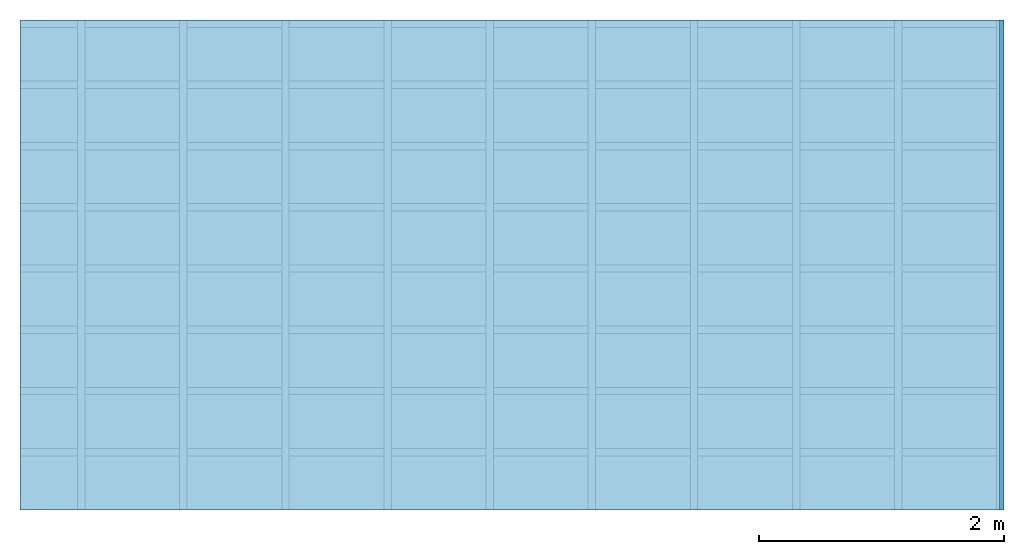
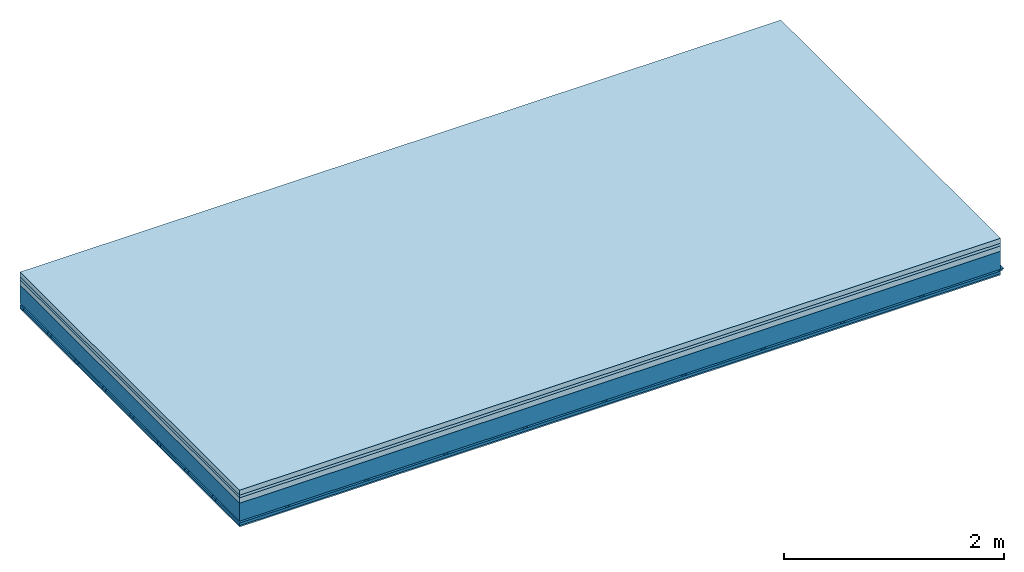
# One storey: 4 members, 4 plates, 1 element without a shape of its own.
"""IFC4 building model written with IfcOpenShell, lengths in metres."""

import ifcopenshell
import ifcopenshell.guid

model = None  # the IFC model being written
_history = None  # IfcOwnerHistory: only IFC2X3 demands one
_inside = {}  # id of a spatial element -> (the spatial element, [elements in it])
_under = {}  # id of a project, library or spatial element -> (it, [spatial elements below it])
_declared = {}  # id of a project -> (the project, [libraries it declares])
_typed = {}  # id of a type object -> (the type object, [elements of that type])
_made_of = {}  # id of a material, layer set ... -> (it, [elements and type objects made of it])


def new_model(schema):
    """Start an empty IFC model of exactly this schema.

    Asked for "IFC4X3", IfcOpenShell would pick the latest addendum, in which some entities
    have other attributes; the version numbers below select the first issue.
    IFC2X3 requires an IfcOwnerHistory on every rooted entity: one is made here for all.
    """
    global model, _history
    if schema == "IFC4X3":
        model = ifcopenshell.file(schema_version=(4, 3, 0, 0))
    else:
        model = ifcopenshell.file(schema=schema)
    _inside.clear()
    _under.clear()
    _declared.clear()
    _typed.clear()
    _made_of.clear()
    _history = None
    if model.schema == "IFC2X3":
        org = make("IfcOrganization", Name="unknown")
        user = make(
            "IfcPersonAndOrganization",
            ThePerson=make("IfcPerson", FamilyName="unknown"),
            TheOrganization=org,
        )
        app = make(
            "IfcApplication",
            ApplicationDeveloper=org,
            Version="unknown",
            ApplicationFullName="unknown",
            ApplicationIdentifier="unknown",
        )
        _history = make(
            "IfcOwnerHistory",
            OwningUser=user,
            OwningApplication=app,
            ChangeAction="ADDED",
            CreationDate=0,
        )
    return model


def make(cls, **values):
    """One entity of the class cls with the attributes given. An attribute that is None is left unset."""
    return model.create_entity(
        cls, **{name: value for name, value in values.items() if value is not None}
    )


def rooted(cls, **values):
    """An entity with a GlobalId (a new one), such as an element, a storey or a relation."""
    return make(cls, GlobalId=ifcopenshell.guid.new(), OwnerHistory=_history, **values)


def si_unit(unit_type, name, prefix=None):
    """IfcSIUnit, for example si_unit("LENGTHUNIT", "METRE", prefix="MILLI")."""
    return make("IfcSIUnit", UnitType=unit_type, Prefix=prefix, Name=name)


def derived_unit(unit_type, elements):
    """IfcDerivedUnit: a product of units, each with its exponent."""
    return make(
        "IfcDerivedUnit",
        Elements=[
            make("IfcDerivedUnitElement", Unit=unit, Exponent=power)
            for unit, power in elements
        ],
        UnitType=unit_type,
    )


def assignment(units):
    """IfcUnitAssignment: the units of a project."""
    return None if units is None else make("IfcUnitAssignment", Units=units)


def point(xyz):
    """IfcCartesianPoint."""
    return None if xyz is None else make("IfcCartesianPoint", Coordinates=xyz)


def direction(xyz):
    """IfcDirection."""
    return None if xyz is None else make("IfcDirection", DirectionRatios=xyz)


def frame(location, z_axis=None, x_axis=None):
    """IfcAxis2Placement3D, a coordinate frame: its origin and axes. An axis left out is left unset."""
    return make(
        "IfcAxis2Placement3D",
        Location=point(location),
        Axis=direction(z_axis),
        RefDirection=direction(x_axis),
    )


def frame_2d(location, x_axis=None):
    """IfcAxis2Placement2D, a coordinate frame in the plane: its origin and x axis."""
    return make(
        "IfcAxis2Placement2D", Location=point(location), RefDirection=direction(x_axis)
    )


def origin():
    """The frame at (0, 0, 0) with its axes left unset."""
    return frame((0.0, 0.0, 0.0))


def origin_with_axes():
    """The frame at (0, 0, 0) with the z axis (0, 0, 1) and the x axis (1, 0, 0) written out."""
    return frame((0.0, 0.0, 0.0), z_axis=(0.0, 0.0, 1.0), x_axis=(1.0, 0.0, 0.0))


def place(relative_to, where):
    """IfcLocalPlacement: puts the frame where relative to a parent placement (None: the world)."""
    return make(
        "IfcLocalPlacement", PlacementRelTo=relative_to, RelativePlacement=where
    )


def context(
    kind, dimensions, precision=None, world=None, true_north=None, identifier=None
):
    """IfcGeometricRepresentationContext, for example the 3D "Model" context."""
    return make(
        "IfcGeometricRepresentationContext",
        ContextIdentifier=identifier,
        ContextType=kind,
        CoordinateSpaceDimension=dimensions,
        Precision=precision,
        WorldCoordinateSystem=world,
        TrueNorth=true_north,
    )


def project(units=None, contexts=None):
    """IfcProject with its units and contexts."""
    return rooted(
        "IfcProject",
        Name="project",
        RepresentationContexts=contexts,
        UnitsInContext=assignment(units),
    )


def spatial(cls, under=None, at=None, **own):
    """A site, building, storey or space (cls), placed at a placement, below another one or the project."""
    s = rooted(cls, ObjectPlacement=at, **own)
    if under is not None:
        _under.setdefault(under.id(), (under, []))[1].append(s)
    return s


def polyline(points):
    """IfcPolyline through the points."""
    return make("IfcPolyline", Points=[point(p) for p in points])


def profile(cls, at=None, kind="AREA", **sizes):
    """A parametric profile (cls). Its sizes go by their IFC names, for example OverallWidth=200.0."""
    return make(cls, ProfileType=kind, Position=at, **sizes)


def rectangle(**sizes):
    """IfcRectangleProfileDef."""
    return profile("IfcRectangleProfileDef", **sizes)


def outline(outer, holes=None, kind="AREA"):
    """IfcArbitraryClosedProfileDef: a profile drawn as a closed curve; with holes, ...WithVoids."""
    if holes is None:
        return make("IfcArbitraryClosedProfileDef", ProfileType=kind, OuterCurve=outer)
    return make(
        "IfcArbitraryProfileDefWithVoids",
        ProfileType=kind,
        OuterCurve=outer,
        InnerCurves=holes,
    )


def extrude(swept, where, along, depth):
    """IfcExtrudedAreaSolid: the profile swept, set in the frame where, extruded along a direction by depth."""
    return make(
        "IfcExtrudedAreaSolid",
        SweptArea=swept,
        Position=where,
        ExtrudedDirection=direction(along),
        Depth=depth,
    )


def shape(context_of_items, identifier, shape_type, items):
    """IfcShapeRepresentation: the items that make up one representation, for example the "Body"."""
    return make(
        "IfcShapeRepresentation",
        ContextOfItems=context_of_items,
        RepresentationIdentifier=identifier,
        RepresentationType=shape_type,
        Items=items,
    )


def material(Name=None, Category=None):
    """IfcMaterial."""
    return make("IfcMaterial", Name=Name, Category=Category)


def layer(
    of_material, thickness, ventilated=None, Name=None, Category=None, Priority=None
):
    """IfcMaterialLayer: one layer of a wall or slab, of a material (None: an air gap)."""
    return make(
        "IfcMaterialLayer",
        Material=of_material,
        LayerThickness=thickness,
        IsVentilated=ventilated,
        Name=Name,
        Category=Category,
        Priority=Priority,
    )


def layer_set(layers, Name=None):
    """IfcMaterialLayerSet."""
    return make("IfcMaterialLayerSet", MaterialLayers=layers, LayerSetName=Name)


def made_of(thing, what):
    """Note that an element or type object is made of a material, layer set ...; save() writes the relation."""
    if what is not None:
        _made_of.setdefault(what.id(), (what, []))[1].append(thing)
    return thing


def type_object(cls, material=None, **own):
    """A type object (cls), such as IfcWallType, which elements share."""
    return made_of(rooted(cls, **own), material)


def element(
    cls,
    number,
    at=None,
    inside=None,
    cuts=None,
    type_object=None,
    material=None,
    context=None,
    identifier="Body",
    shape_type=None,
    held_by="IfcProductDefinitionShape",
    body=None,
    shapes=None,
    **own,
):
    """One element of the class cls, such as IfcWall. Its Tag is "e" and its number.

    at: its placement. inside: the storey or other place that contains it. cuts: it is an
    opening in that element (IfcRelVoidsElement). A single representation is given by context,
    identifier, shape_type and body (its items); several are given by shapes. held_by: the class
    of the entity that holds the representations. save() writes the other relations.
    """
    e = rooted(cls, Tag="e%d" % number, ObjectPlacement=at, **own)
    if body is not None:
        shapes = [shape(context, identifier, shape_type, body)]
    if shapes is not None:
        e.Representation = make(held_by, Representations=shapes)
    if inside is not None:
        _inside.setdefault(inside.id(), (inside, []))[1].append(e)
    if cuts is not None:
        rooted(
            "IfcRelVoidsElement", RelatingBuildingElement=cuts, RelatedOpeningElement=e
        )
    if type_object is not None:
        _typed.setdefault(type_object.id(), (type_object, []))[1].append(e)
    return made_of(e, material)


def aggregate(whole, parts):
    """IfcRelAggregates: a whole, such as a stair, and the parts it consists of."""
    return rooted("IfcRelAggregates", RelatingObject=whole, RelatedObjects=parts)


def save(model, path):
    """Write the relations noted so far, then the file.

    IfcRelAggregates (storeys below a building ...), IfcRelContainedInSpatialStructure (elements
    in a storey), IfcRelDefinesByType, IfcRelAssociatesMaterial and IfcRelDeclares: one each for
    every whole, place, type object, material and project.
    """
    for whole, parts in _under.values():
        aggregate(whole, parts)
    for where, things in _inside.values():
        rooted(
            "IfcRelContainedInSpatialStructure",
            RelatedElements=things,
            RelatingStructure=where,
        )
    for kind, things in _typed.values():
        rooted("IfcRelDefinesByType", RelatedObjects=things, RelatingType=kind)
    for what, things in _made_of.values():
        rooted("IfcRelAssociatesMaterial", RelatedObjects=things, RelatingMaterial=what)
    for by, libraries in _declared.values():
        rooted("IfcRelDeclares", RelatingContext=by, RelatedDefinitions=libraries)
    model.write(path)


model = new_model("IFC4")

# Units and contexts
plan_context = context("Plan", 3, precision=1e-05, world=origin(), true_north=direction((0.0, 1.0)))
model_context = context("Model", 3, precision=1e-05, world=origin(), true_north=direction((0.0, 1.0)))
ifc_project = project(units=[si_unit("LENGTHUNIT", "METRE"), derived_unit("SOUNDPRESSUREUNIT", [(si_unit("PRESSUREUNIT", "PASCAL", prefix="MICRO"), 0)]), si_unit("ENERGYUNIT", "JOULE", prefix="MEGA"), si_unit("MASSUNIT", "GRAM", prefix="KILO"), derived_unit("THERMALTRANSMITTANCEUNIT", [(si_unit("POWERUNIT", "WATT"), 1), (si_unit("AREAUNIT", "SQUARE_METRE"), -1), (si_unit("THERMODYNAMICTEMPERATUREUNIT", "KELVIN"), -1)]), derived_unit("AREADENSITYUNIT", [(si_unit("MASSUNIT", "GRAM", prefix="KILO"), 1), (si_unit("AREAUNIT", "SQUARE_METRE"), -1)]), derived_unit("USERDEFINED", [(si_unit("ENERGYUNIT", "JOULE", prefix="MEGA"), 1), (si_unit("AREAUNIT", "SQUARE_METRE"), -1)])], contexts=[plan_context, model_context])

# Site, building, storey
site = spatial("IfcSite", under=ifc_project)
building_placement = place(None, origin())
building = spatial("IfcBuilding", under=site, at=building_placement)
storey_placement = place(building_placement, origin())
storey = spatial("IfcBuildingStorey", under=building, at=storey_placement)

# Slab, members, plates
ifc_material_1 = material(Category="04.005")
ifc_layer_1 = layer(ifc_material_1, 0.055, Name="On-material")
ifc_material_2 = material()
ifc_layer_2 = layer(ifc_material_2, 0.03, Name="Impact sound insulation")
ifc_material_3 = material(Category="03.011")
ifc_layer_3 = layer(ifc_material_3, 0.06, Name="on Supporting structure")
ifc_layer_4 = layer(None, 0.2, Name="Supporting structure")
ifc_material_4 = material(Name="no composite action")
ifc_layer_5 = layer(ifc_material_4, 0.0, Name="Bond")
ifc_layer_6 = layer(None, 0.02, Name="Coupling")
ifc_layer_7 = layer(None, 0.03, Name="Battens / profiles")
ifc_material_5 = material(Category="03.007")
ifc_layer_8 = layer(ifc_material_5, 0.015, Name="Ceiling covering 1st layer")
ifc_material_6 = material(Name="Glued joints")
ifc_layer_9 = layer(ifc_material_6, 0.0, Name="Surface / treatment")
ifc_layer_set = layer_set([ifc_layer_1, ifc_layer_2, ifc_layer_3, ifc_layer_4, ifc_layer_5, ifc_layer_6, ifc_layer_7, ifc_layer_8, ifc_layer_9])
slab_type = type_object("IfcSlabType", Name="A1125", PredefinedType="NOTDEFINED", material=ifc_layer_set)
slab_placement = place(None, frame((0.0, 0.0, 0.0), z_axis=(0.0, 0.0, -1.0), x_axis=(1.0, 0.0, 0.0)))
slab = element("IfcSlab", 1, at=slab_placement, inside=storey, type_object=slab_type, material=ifc_layer_set, Name="Slab #1")
ifc_material_7 = material()
member_1_placement = place(slab_placement, origin())
member_1 = element("IfcMember", 2, at=member_1_placement, material=ifc_material_7, Name="Supporting structure", context=plan_context, shape_type="SweptSolid", body=[
    extrude(rectangle(XDim=1.0, YDim=0.2, at=frame_2d((0.5, 0.1), x_axis=(1.0, 0.0))), frame((0.0, 4.0, 0.145), z_axis=(0.0, -1.0, 0.0), x_axis=(1.0, 0.0, 0.0)), (0.0, 0.0, 1.0), 4.0),
    extrude(rectangle(XDim=1.0, YDim=0.2, at=frame_2d((0.5, 0.1), x_axis=(1.0, 0.0))), frame((1.0, 4.0, 0.145), z_axis=(0.0, -1.0, 0.0), x_axis=(1.0, 0.0, 0.0)), (0.0, 0.0, 1.0), 4.0),
    extrude(rectangle(XDim=1.0, YDim=0.2, at=frame_2d((0.5, 0.1), x_axis=(1.0, 0.0))), frame((2.0, 4.0, 0.145), z_axis=(0.0, -1.0, 0.0), x_axis=(1.0, 0.0, 0.0)), (0.0, 0.0, 1.0), 4.0),
    extrude(rectangle(XDim=1.0, YDim=0.2, at=frame_2d((0.5, 0.1), x_axis=(1.0, 0.0))), frame((3.0, 4.0, 0.145), z_axis=(0.0, -1.0, 0.0), x_axis=(1.0, 0.0, 0.0)), (0.0, 0.0, 1.0), 4.0),
    extrude(rectangle(XDim=1.0, YDim=0.2, at=frame_2d((0.5, 0.1), x_axis=(1.0, 0.0))), frame((4.0, 4.0, 0.145), z_axis=(0.0, -1.0, 0.0), x_axis=(1.0, 0.0, 0.0)), (0.0, 0.0, 1.0), 4.0),
    extrude(rectangle(XDim=1.0, YDim=0.2, at=frame_2d((0.5, 0.1), x_axis=(1.0, 0.0))), frame((5.0, 4.0, 0.145), z_axis=(0.0, -1.0, 0.0), x_axis=(1.0, 0.0, 0.0)), (0.0, 0.0, 1.0), 4.0),
    extrude(rectangle(XDim=1.0, YDim=0.2, at=frame_2d((0.5, 0.1), x_axis=(1.0, 0.0))), frame((6.0, 4.0, 0.145), z_axis=(0.0, -1.0, 0.0), x_axis=(1.0, 0.0, 0.0)), (0.0, 0.0, 1.0), 4.0),
    extrude(rectangle(XDim=1.0, YDim=0.2, at=frame_2d((0.5, 0.1), x_axis=(1.0, 0.0))), frame((7.0, 4.0, 0.145), z_axis=(0.0, -1.0, 0.0), x_axis=(1.0, 0.0, 0.0)), (0.0, 0.0, 1.0), 4.0),
])
ifc_material_8 = material()
member_2_placement = place(slab_placement, origin())
member_2 = element("IfcMember", 3, at=member_2_placement, material=ifc_material_8, Name="Coupling", context=plan_context, shape_type="SweptSolid", body=[
    extrude(outline(polyline([(0.0, 0.0), (0.06, 0.0), (0.04, 0.02), (0.02, 0.02), (0.0, 0.0)])), frame((0.47, 4.0, 0.345), z_axis=(0.0, -1.0, 0.0), x_axis=(1.0, 0.0, 0.0)), (0.0, 0.0, 1.0), 4.0),
    extrude(outline(polyline([(0.0, 0.0), (0.06, 0.0), (0.04, 0.02), (0.02, 0.02), (0.0, 0.0)])), frame((1.304, 4.0, 0.345), z_axis=(0.0, -1.0, 0.0), x_axis=(1.0, 0.0, 0.0)), (0.0, 0.0, 1.0), 4.0),
    extrude(outline(polyline([(0.0, 0.0), (0.06, 0.0), (0.04, 0.02), (0.02, 0.02), (0.0, 0.0)])), frame((2.138, 4.0, 0.345), z_axis=(0.0, -1.0, 0.0), x_axis=(1.0, 0.0, 0.0)), (0.0, 0.0, 1.0), 4.0),
    extrude(outline(polyline([(0.0, 0.0), (0.06, 0.0), (0.04, 0.02), (0.02, 0.02), (0.0, 0.0)])), frame((2.972, 4.0, 0.345), z_axis=(0.0, -1.0, 0.0), x_axis=(1.0, 0.0, 0.0)), (0.0, 0.0, 1.0), 4.0),
    extrude(outline(polyline([(0.0, 0.0), (0.06, 0.0), (0.04, 0.02), (0.02, 0.02), (0.0, 0.0)])), frame((3.806, 4.0, 0.345), z_axis=(0.0, -1.0, 0.0), x_axis=(1.0, 0.0, 0.0)), (0.0, 0.0, 1.0), 4.0),
    extrude(outline(polyline([(0.0, 0.0), (0.06, 0.0), (0.04, 0.02), (0.02, 0.02), (0.0, 0.0)])), frame((4.64, 4.0, 0.345), z_axis=(0.0, -1.0, 0.0), x_axis=(1.0, 0.0, 0.0)), (0.0, 0.0, 1.0), 4.0),
    extrude(outline(polyline([(0.0, 0.0), (0.06, 0.0), (0.04, 0.02), (0.02, 0.02), (0.0, 0.0)])), frame((5.474, 4.0, 0.345), z_axis=(0.0, -1.0, 0.0), x_axis=(1.0, 0.0, 0.0)), (0.0, 0.0, 1.0), 4.0),
    extrude(outline(polyline([(0.0, 0.0), (0.06, 0.0), (0.04, 0.02), (0.02, 0.02), (0.0, 0.0)])), frame((6.308, 4.0, 0.345), z_axis=(0.0, -1.0, 0.0), x_axis=(1.0, 0.0, 0.0)), (0.0, 0.0, 1.0), 4.0),
    extrude(outline(polyline([(0.0, 0.0), (0.06, 0.0), (0.04, 0.02), (0.02, 0.02), (0.0, 0.0)])), frame((7.142, 4.0, 0.345), z_axis=(0.0, -1.0, 0.0), x_axis=(1.0, 0.0, 0.0)), (0.0, 0.0, 1.0), 4.0),
    extrude(outline(polyline([(0.0, 0.0), (0.06, 0.0), (0.04, 0.02), (0.02, 0.02), (0.0, 0.0)])), frame((7.976, 4.0, 0.345), z_axis=(0.0, -1.0, 0.0), x_axis=(1.0, 0.0, 0.0)), (0.0, 0.0, 1.0), 4.0),
])
ifc_material_9 = material()
member_3_placement = place(slab_placement, origin())
member_3 = element("IfcMember", 4, at=member_3_placement, material=ifc_material_9, Name="Battens / profiles", context=plan_context, shape_type="SweptSolid", body=[
    extrude(rectangle(XDim=0.06, YDim=0.03, at=frame_2d((0.03, 0.015), x_axis=(1.0, 0.0))), frame((0.0, 0.0, 0.365), z_axis=(1.0, 0.0, 0.0), x_axis=(0.0, 1.0, 0.0)), (0.0, 0.0, 1.0), 8.0),
    extrude(rectangle(XDim=0.06, YDim=0.03, at=frame_2d((0.03, 0.015), x_axis=(1.0, 0.0))), frame((0.0, 0.5, 0.365), z_axis=(1.0, 0.0, 0.0), x_axis=(0.0, 1.0, 0.0)), (0.0, 0.0, 1.0), 8.0),
    extrude(rectangle(XDim=0.06, YDim=0.03, at=frame_2d((0.03, 0.015), x_axis=(1.0, 0.0))), frame((0.0, 1.0, 0.365), z_axis=(1.0, 0.0, 0.0), x_axis=(0.0, 1.0, 0.0)), (0.0, 0.0, 1.0), 8.0),
    extrude(rectangle(XDim=0.06, YDim=0.03, at=frame_2d((0.03, 0.015), x_axis=(1.0, 0.0))), frame((0.0, 1.5, 0.365), z_axis=(1.0, 0.0, 0.0), x_axis=(0.0, 1.0, 0.0)), (0.0, 0.0, 1.0), 8.0),
    extrude(rectangle(XDim=0.06, YDim=0.03, at=frame_2d((0.03, 0.015), x_axis=(1.0, 0.0))), frame((0.0, 2.0, 0.365), z_axis=(1.0, 0.0, 0.0), x_axis=(0.0, 1.0, 0.0)), (0.0, 0.0, 1.0), 8.0),
    extrude(rectangle(XDim=0.06, YDim=0.03, at=frame_2d((0.03, 0.015), x_axis=(1.0, 0.0))), frame((0.0, 2.5, 0.365), z_axis=(1.0, 0.0, 0.0), x_axis=(0.0, 1.0, 0.0)), (0.0, 0.0, 1.0), 8.0),
    extrude(rectangle(XDim=0.06, YDim=0.03, at=frame_2d((0.03, 0.015), x_axis=(1.0, 0.0))), frame((0.0, 3.0, 0.365), z_axis=(1.0, 0.0, 0.0), x_axis=(0.0, 1.0, 0.0)), (0.0, 0.0, 1.0), 8.0),
    extrude(rectangle(XDim=0.06, YDim=0.03, at=frame_2d((0.03, 0.015), x_axis=(1.0, 0.0))), frame((0.0, 3.5, 0.365), z_axis=(1.0, 0.0, 0.0), x_axis=(0.0, 1.0, 0.0)), (0.0, 0.0, 1.0), 8.0),
])
ifc_material_10 = material()
member_4_placement = place(slab_placement, origin())
member_4 = element("IfcMember", 5, at=member_4_placement, material=ifc_material_10, Name="Cavity", context=plan_context, shape_type="SweptSolid", body=[
    extrude(rectangle(XDim=0.44, YDim=0.03, at=frame_2d((0.22, 0.015), x_axis=(1.0, 0.0))), frame((0.0, 0.06, 0.365), z_axis=(1.0, 0.0, 0.0), x_axis=(0.0, 1.0, 0.0)), (0.0, 0.0, 1.0), 8.0),
    extrude(rectangle(XDim=0.44, YDim=0.03, at=frame_2d((0.22, 0.015), x_axis=(1.0, 0.0))), frame((0.0, 0.56, 0.365), z_axis=(1.0, 0.0, 0.0), x_axis=(0.0, 1.0, 0.0)), (0.0, 0.0, 1.0), 8.0),
    extrude(rectangle(XDim=0.44, YDim=0.03, at=frame_2d((0.22, 0.015), x_axis=(1.0, 0.0))), frame((0.0, 1.06, 0.365), z_axis=(1.0, 0.0, 0.0), x_axis=(0.0, 1.0, 0.0)), (0.0, 0.0, 1.0), 8.0),
    extrude(rectangle(XDim=0.44, YDim=0.03, at=frame_2d((0.22, 0.015), x_axis=(1.0, 0.0))), frame((0.0, 1.56, 0.365), z_axis=(1.0, 0.0, 0.0), x_axis=(0.0, 1.0, 0.0)), (0.0, 0.0, 1.0), 8.0),
    extrude(rectangle(XDim=0.44, YDim=0.03, at=frame_2d((0.22, 0.015), x_axis=(1.0, 0.0))), frame((0.0, 2.06, 0.365), z_axis=(1.0, 0.0, 0.0), x_axis=(0.0, 1.0, 0.0)), (0.0, 0.0, 1.0), 8.0),
    extrude(rectangle(XDim=0.44, YDim=0.03, at=frame_2d((0.22, 0.015), x_axis=(1.0, 0.0))), frame((0.0, 2.56, 0.365), z_axis=(1.0, 0.0, 0.0), x_axis=(0.0, 1.0, 0.0)), (0.0, 0.0, 1.0), 8.0),
    extrude(rectangle(XDim=0.44, YDim=0.03, at=frame_2d((0.22, 0.015), x_axis=(1.0, 0.0))), frame((0.0, 3.06, 0.365), z_axis=(1.0, 0.0, 0.0), x_axis=(0.0, 1.0, 0.0)), (0.0, 0.0, 1.0), 8.0),
    extrude(rectangle(XDim=0.44, YDim=0.03, at=frame_2d((0.22, 0.015), x_axis=(1.0, 0.0))), frame((0.0, 3.56, 0.365), z_axis=(1.0, 0.0, 0.0), x_axis=(0.0, 1.0, 0.0)), (0.0, 0.0, 1.0), 8.0),
])
plate_1_placement = place(slab_placement, origin())
plate_1 = element("IfcPlate", 6, at=plate_1_placement, material=ifc_material_1, Name="On-material", context=plan_context, shape_type="SweptSolid", body=[
    extrude(rectangle(XDim=8.0, YDim=4.0, at=frame_2d((4.0, 2.0), x_axis=(1.0, 0.0))), origin_with_axes(), (0.0, 0.0, 1.0), 0.055),
])
plate_2_placement = place(slab_placement, origin())
plate_2 = element("IfcPlate", 7, at=plate_2_placement, material=ifc_material_2, Name="Impact sound insulation", context=plan_context, shape_type="SweptSolid", body=[
    extrude(rectangle(XDim=8.0, YDim=4.0, at=frame_2d((4.0, 2.0), x_axis=(1.0, 0.0))), frame((0.0, 0.0, 0.055), z_axis=(0.0, 0.0, 1.0), x_axis=(1.0, 0.0, 0.0)), (0.0, 0.0, 1.0), 0.03),
])
plate_3_placement = place(slab_placement, origin())
plate_3 = element("IfcPlate", 8, at=plate_3_placement, material=ifc_material_3, Name="on Supporting structure", context=plan_context, shape_type="SweptSolid", body=[
    extrude(rectangle(XDim=8.0, YDim=4.0, at=frame_2d((4.0, 2.0), x_axis=(1.0, 0.0))), frame((0.0, 0.0, 0.085), z_axis=(0.0, 0.0, 1.0), x_axis=(1.0, 0.0, 0.0)), (0.0, 0.0, 1.0), 0.06),
])
plate_4_placement = place(slab_placement, origin())
plate_4 = element("IfcPlate", 9, at=plate_4_placement, material=ifc_material_5, Name="Ceiling covering 1st layer", context=plan_context, shape_type="SweptSolid", body=[
    extrude(rectangle(XDim=8.0, YDim=4.0, at=frame_2d((4.0, 2.0), x_axis=(1.0, 0.0))), frame((0.0, 0.0, 0.395), z_axis=(0.0, 0.0, 1.0), x_axis=(1.0, 0.0, 0.0)), (0.0, 0.0, 1.0), 0.015),
])
aggregate(slab, [plate_1, plate_2, plate_3, member_1, member_2, member_3, member_4, plate_4])

save(model, "model.ifc")
